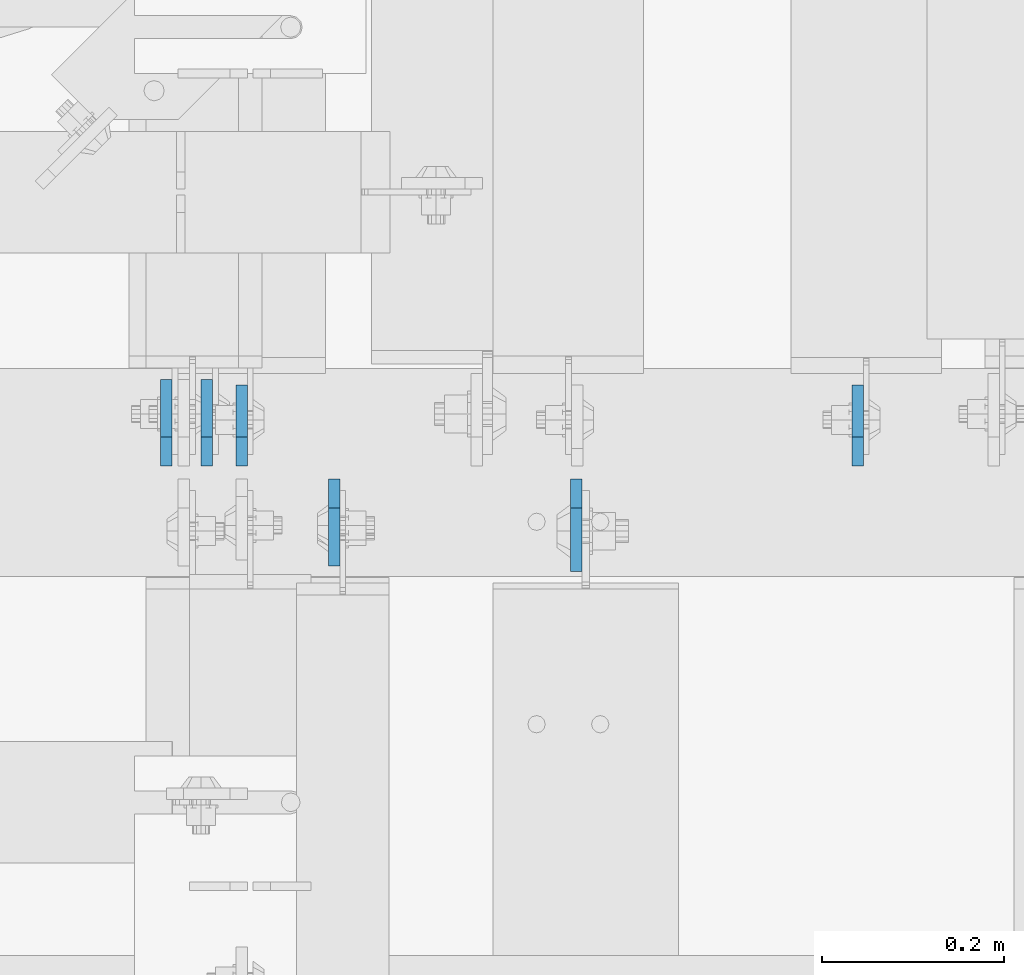
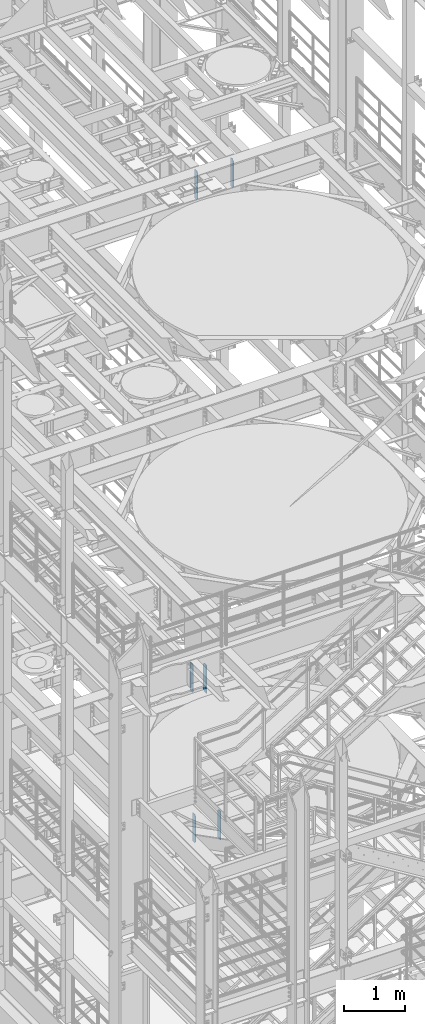
# One storey, part 1584 of 1876: 6 plates, 3 elements without a shape of their own.
"""IFC2X3 building model written with IfcOpenShell, lengths in millimetres."""

from ifc_helpers import new_model, si_unit, frame, origin_with_axes, place, context, subcontext, project, spatial, faceted_brep, material, type_object, element, aggregate, save


model = new_model("IFC2X3")

# Units and contexts
model_context = context("Model", 3, precision=1e-05, world=origin_with_axes())
body_context = subcontext(model_context, "Body", "Model", "MODEL_VIEW")
ifc_project = project(units=[si_unit("LENGTHUNIT", "METRE", prefix="MILLI"), si_unit("AREAUNIT", "SQUARE_METRE"), si_unit("VOLUMEUNIT", "CUBIC_METRE"), si_unit("MASSUNIT", "GRAM", prefix="KILO"), si_unit("TIMEUNIT", "SECOND"), si_unit("PLANEANGLEUNIT", "RADIAN"), si_unit("SOLIDANGLEUNIT", "STERADIAN"), si_unit("THERMODYNAMICTEMPERATUREUNIT", "DEGREE_CELSIUS"), si_unit("LUMINOUSINTENSITYUNIT", "LUMEN")], contexts=[model_context])

# Site, building, storey
site_placement = place(None, origin_with_axes())
site = spatial("IfcSite", under=ifc_project, at=site_placement, CompositionType="ELEMENT")
building_placement = place(site_placement, origin_with_axes())
building = spatial("IfcBuilding", under=site, at=building_placement, Name="Undefined", CompositionType="ELEMENT")
storey_placement = place(building_placement, origin_with_axes())
storey = spatial("IfcBuildingStorey", under=building, at=storey_placement, Name="Undefined", CompositionType="ELEMENT", Elevation=0.0)

# Assembly, plates
assembly_1_placement = place(storey_placement, origin_with_axes())
assembly_1 = element("IfcElementAssembly", 1, at=assembly_1_placement, inside=storey, Name="BEAM", AssemblyPlace="NOTDEFINED", PredefinedType="RIGID_FRAME")
ifc_material = material(Name="STEEL/A36")
plate_type_1 = type_object("IfcPlateType", PredefinedType="NOTDEFINED")
plate_1_placement = place(assembly_1_placement, frame((5492.74999990463, 1531.14375, 17386.3), z_axis=(0.0, 0.0, 1.0), x_axis=(0.0, 1.0, 0.0)))
plate_1 = element("IfcPlate", 2, at=plate_1_placement, type_object=plate_type_1, material=ifc_material, Name="PLATE", context=body_context, shape_type="Brep", body=[
    faceted_brep([(0.0, -6.34999999999991, 31.75), (0.0, -6.34999999999991, 539.75), (0.0, 6.34999999999991, 539.75), (0.0, 6.34999999999991, 31.75), (31.75, -6.34999999999991, 571.5), (31.75, 6.34999999999991, 571.5), (88.9000015258789, -6.34999999999991, 571.5), (88.9000015258789, 6.34999999999991, 571.5), (88.9000015258789, -6.34999999999991, 0.0), (88.9000015258789, 6.34999999999991, 0.0), (31.75, -6.34999999999991, 0.0), (31.75, 6.34999999999991, 0.0)], [[[0, 1, 2, 3]], [[1, 4, 5, 2]], [[4, 6, 7, 5]], [[6, 8, 9, 7]], [[8, 10, 11, 9]], [[10, 0, 3, 11]], [[5, 7, 9, 11, 3, 2]], [[10, 8, 6, 4, 1, 0]]]),
])
plate_2_placement = place(assembly_1_placement, frame((4816.47499990463, 1531.14375, 17386.3), z_axis=(0.0, 0.0, 1.0), x_axis=(0.0, 1.0, 0.0)))
plate_2 = element("IfcPlate", 3, at=plate_2_placement, type_object=plate_type_1, material=ifc_material, Name="PLATE", context=body_context, shape_type="Brep", body=[
    faceted_brep([(0.0, -6.34999999999991, 31.75), (0.0, -6.34999999999991, 539.75), (0.0, 6.34999999999991, 539.75), (0.0, 6.34999999999991, 31.75), (31.75, -6.34999999999991, 571.5), (31.75, 6.34999999999991, 571.5), (88.9000015258789, -6.34999999999991, 571.5), (88.9000015258789, 6.34999999999991, 571.5), (88.9000015258789, -6.34999999999991, 0.0), (88.9000015258789, 6.34999999999991, 0.0), (31.75, -6.34999999999991, 0.0), (31.75, 6.34999999999991, 0.0)], [[[0, 1, 2, 3]], [[1, 4, 5, 2]], [[4, 6, 7, 5]], [[6, 8, 9, 7]], [[8, 10, 11, 9]], [[10, 0, 3, 11]], [[5, 7, 9, 11, 3, 2]], [[10, 8, 6, 4, 1, 0]]]),
])
aggregate(assembly_1, [plate_1, plate_2])

assembly_2_placement = place(storey_placement, origin_with_axes())
assembly_2 = element("IfcElementAssembly", 4, at=assembly_2_placement, inside=storey, Name="BEAM", AssemblyPlace="NOTDEFINED", PredefinedType="RIGID_FRAME")
plate_type_2 = type_object("IfcPlateType", PredefinedType="NOTDEFINED")
plate_3_placement = place(assembly_2_placement, frame((4918.07499990463, 1516.85625, 7558.0875), z_axis=(0.0, 0.0, 1.0), x_axis=(0.0, -1.0, 0.0)))
plate_3 = element("IfcPlate", 5, at=plate_3_placement, type_object=plate_type_2, material=ifc_material, Name="PLATE", context=body_context, shape_type="Brep", body=[
    faceted_brep([(0.0, -6.34999999999991, 31.75), (0.0, -6.35000000000036, 538.162475585938), (0.0, 6.35000000000036, 538.162475585938), (0.0, 6.34999999999991, 31.75), (31.75, -6.35000000000036, 569.912475585938), (31.75, 6.35000000000036, 569.912475585938), (95.25, -6.35000000000036, 569.912475585938), (95.25, 6.35000000000036, 569.912475585938), (95.25, -6.35000000000036, 0.0), (95.25, 6.35000000000036, 0.0), (31.75, -6.34999999999991, 0.0), (31.75, 6.34999999999991, 0.0)], [[[0, 1, 2, 3]], [[1, 4, 5, 2]], [[4, 6, 7, 5]], [[6, 8, 9, 7]], [[8, 10, 11, 9]], [[10, 0, 3, 11]], [[5, 7, 9, 11, 3, 2]], [[10, 8, 6, 4, 1, 0]]]),
])
plate_4_placement = place(assembly_2_placement, frame((4733.92499990463, 1531.14375, 7558.0875), z_axis=(0.0, 0.0, 1.0), x_axis=(0.0, 1.0, 0.0)))
plate_4 = element("IfcPlate", 6, at=plate_4_placement, type_object=plate_type_2, material=ifc_material, Name="PLATE", context=body_context, shape_type="Brep", body=[
    faceted_brep([(0.0, -6.34999999999991, 31.75), (0.0, -6.35000000000036, 538.162475585938), (0.0, 6.35000000000036, 538.162475585938), (0.0, 6.34999999999991, 31.75), (31.75, -6.35000000000036, 569.912475585938), (31.75, 6.35000000000036, 569.912475585938), (95.25, -6.35000000000036, 569.912475585938), (95.25, 6.35000000000036, 569.912475585938), (95.25, -6.35000000000036, 0.0), (95.25, 6.35000000000036, 0.0), (31.75, -6.34999999999991, 0.0), (31.75, 6.34999999999991, 0.0)], [[[0, 1, 2, 3]], [[1, 4, 5, 2]], [[4, 6, 7, 5]], [[6, 8, 9, 7]], [[8, 10, 11, 9]], [[10, 0, 3, 11]], [[5, 7, 9, 11, 3, 2]], [[10, 8, 6, 4, 1, 0]]]),
])
aggregate(assembly_2, [plate_3, plate_4])

assembly_3_placement = place(storey_placement, origin_with_axes())
assembly_3 = element("IfcElementAssembly", 7, at=assembly_3_placement, inside=storey, Name="BEAM", AssemblyPlace="NOTDEFINED", PredefinedType="RIGID_FRAME")
plate_5_placement = place(assembly_3_placement, frame((4778.37499990463, 1531.14375, 4535.4875), z_axis=(0.0, 0.0, 1.0), x_axis=(0.0, 1.0, 0.0)))
plate_5 = element("IfcPlate", 8, at=plate_5_placement, type_object=plate_type_2, material=ifc_material, Name="PLATE", context=body_context, shape_type="Brep", body=[
    faceted_brep([(0.0, -6.34999999999991, 31.75), (0.0, -6.35000000000036, 538.162475585938), (0.0, 6.35000000000036, 538.162475585938), (0.0, 6.34999999999991, 31.75), (31.75, -6.35000000000036, 569.912475585938), (31.75, 6.35000000000036, 569.912475585938), (95.25, -6.35000000000036, 569.912475585938), (95.25, 6.35000000000036, 569.912475585938), (95.25, -6.35000000000036, 0.0), (95.25, 6.35000000000036, 0.0), (31.75, -6.34999999999991, 0.0), (31.75, 6.34999999999991, 0.0)], [[[0, 1, 2, 3]], [[1, 4, 5, 2]], [[4, 6, 7, 5]], [[6, 8, 9, 7]], [[8, 10, 11, 9]], [[10, 0, 3, 11]], [[5, 7, 9, 11, 3, 2]], [[10, 8, 6, 4, 1, 0]]]),
])
plate_type_3 = type_object("IfcPlateType", PredefinedType="NOTDEFINED")
plate_6_placement = place(assembly_3_placement, frame((5183.98124990463, 1516.85625, 4535.4875), z_axis=(0.0, 0.0, 1.0), x_axis=(0.0, -1.0, 0.0)))
plate_6 = element("IfcPlate", 9, at=plate_6_placement, type_object=plate_type_3, material=ifc_material, Name="PLATE", context=body_context, shape_type="Brep", body=[
    faceted_brep([(0.0, -6.34999999999991, 31.75), (0.0, -6.35000000000036, 538.162475585938), (0.0, 6.35000000000036, 538.162475585938), (0.0, 6.34999999999991, 31.75), (31.75, -6.35000000000036, 569.912475585938), (31.75, 6.35000000000036, 569.912475585938), (101.599998474121, -6.34999999999991, 569.912475585938), (101.599998474121, 6.34999999999991, 569.912475585938), (101.599998474121, -6.35000000000036, 0.0), (101.599998474121, 6.35000000000036, 0.0), (31.75, -6.34999999999991, 0.0), (31.75, 6.34999999999991, 0.0)], [[[0, 1, 2, 3]], [[1, 4, 5, 2]], [[4, 6, 7, 5]], [[6, 8, 9, 7]], [[8, 10, 11, 9]], [[10, 0, 3, 11]], [[5, 7, 9, 11, 3, 2]], [[10, 8, 6, 4, 1, 0]]]),
])
aggregate(assembly_3, [plate_6, plate_5])

save(model, "model.ifc")
